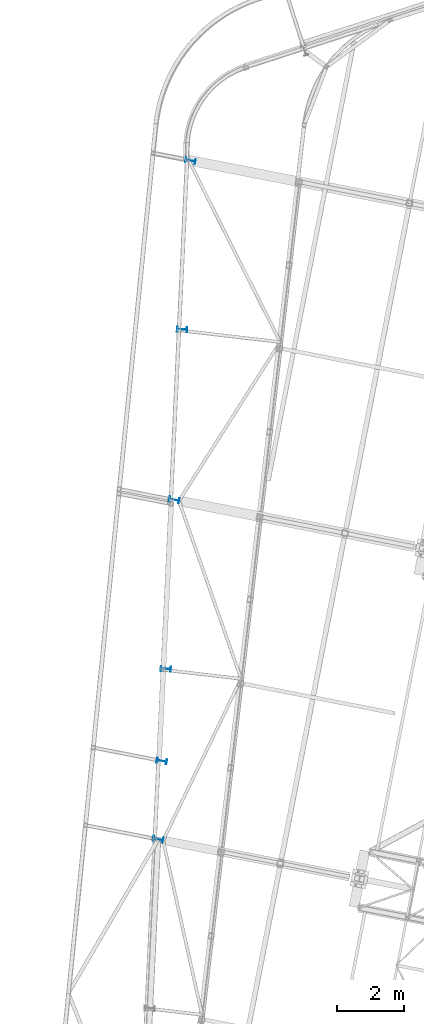
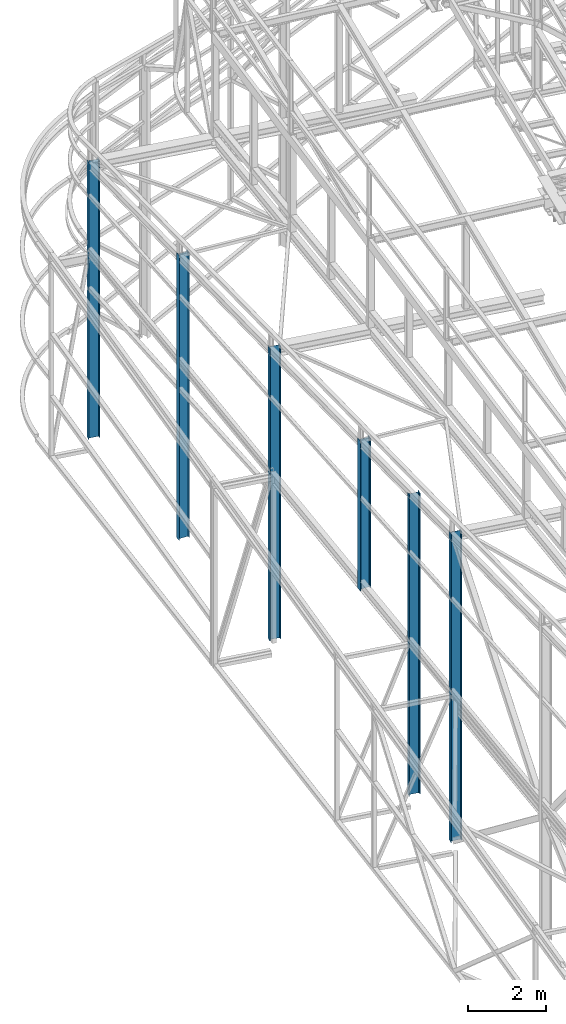
# One storey, part 5 of 215: 6 columns, 6 elements without a shape of their own.
"""IFC2X3 building model written with IfcOpenShell, lengths in millimetres."""

from ifc_helpers import new_model, si_unit, frame, origin_with_axes, origin_2d_with_axis, place, context, subcontext, project, spatial, i_section, extrude, material, type_object, element, aggregate, save


model = new_model("IFC2X3")

# Units and contexts
model_context = context("Model", 3, precision=1e-05, world=origin_with_axes())
body_context = subcontext(model_context, "Body", "Model", "MODEL_VIEW")
ifc_project = project(units=[si_unit("LENGTHUNIT", "METRE", prefix="MILLI"), si_unit("AREAUNIT", "SQUARE_METRE"), si_unit("VOLUMEUNIT", "CUBIC_METRE"), si_unit("MASSUNIT", "GRAM", prefix="KILO"), si_unit("TIMEUNIT", "SECOND"), si_unit("PLANEANGLEUNIT", "RADIAN"), si_unit("SOLIDANGLEUNIT", "STERADIAN"), si_unit("THERMODYNAMICTEMPERATUREUNIT", "DEGREE_CELSIUS"), si_unit("LUMINOUSINTENSITYUNIT", "LUMEN")], contexts=[model_context])

# Site, building, storey
site_placement = place(None, origin_with_axes())
site = spatial("IfcSite", under=ifc_project, at=site_placement, CompositionType="ELEMENT")
building_placement = place(site_placement, origin_with_axes())
building = spatial("IfcBuilding", under=site, at=building_placement, Name="Undefined", CompositionType="ELEMENT")
storey_placement = place(building_placement, origin_with_axes())
storey = spatial("IfcBuildingStorey", under=building, at=storey_placement, Name="Undefined", CompositionType="ELEMENT", Elevation=0.0)

# Assembly, column
assembly_1_placement = place(storey_placement, origin_with_axes())
assembly_1 = element("IfcElementAssembly", 1, at=assembly_1_placement, inside=storey, Name="Steel Assembly", AssemblyPlace="NOTDEFINED", PredefinedType="RIGID_FRAME")
ifc_material = material(Name="STEEL/S275JR")
column_type = type_object("IfcColumnType", Name="IPE300", PredefinedType="NOTDEFINED")
column_1_placement = place(assembly_1_placement, frame((38415.167229992, 39235.4405524724, 4711.42611583732), z_axis=(0.0, 0.0, 1.0), x_axis=(-0.998865584637834, 0.0476187339827342, 0.0)))
column_1 = element("IfcColumn", 2, at=column_1_placement, type_object=column_type, material=ifc_material, Name="MONTANT", ObjectType="IPE300", context=body_context, shape_type="SweptSolid", body=[
    extrude(i_section(OverallWidth=150.0, OverallDepth=300.0, WebThickness=7.099999905, FlangeThickness=10.69999981, FilletRadius=15.0, at=origin_2d_with_axis()), frame((0.0, 0.0, 4682.42655784065), z_axis=(0.0, 0.0, -1.0), x_axis=(0.0, 1.0, 0.0)), (0.0, 0.0, 1.0), 4682.4),
])
aggregate(assembly_1, [column_1])

assembly_2_placement = place(storey_placement, origin_with_axes())
assembly_2 = element("IfcElementAssembly", 3, at=assembly_2_placement, inside=storey, Name="Steel Assembly", AssemblyPlace="NOTDEFINED", PredefinedType="RIGID_FRAME")
column_2_placement = place(assembly_2_placement, frame((38896.164283478, 49328.6883093146, 0.00149246255637933), z_axis=(0.0, 0.0, 1.0), x_axis=(-0.998865584637834, 0.0476187339827342, 0.0)))
column_2 = element("IfcColumn", 4, at=column_2_placement, type_object=column_type, material=ifc_material, Name="MONTANT", ObjectType="IPE300", context=body_context, shape_type="SweptSolid", body=[
    extrude(i_section(OverallWidth=150.0, OverallDepth=300.0, WebThickness=7.099999905, FlangeThickness=10.69999981, FilletRadius=15.0, at=origin_2d_with_axis()), frame((0.0, 0.0, 8896.05310158073), z_axis=(0.0, 0.0, -1.0), x_axis=(0.0, 1.0, 0.0)), (0.0, 0.0, 1.0), 8896.1),
])
aggregate(assembly_2, [column_2])

assembly_3_placement = place(storey_placement, origin_with_axes())
assembly_3 = element("IfcElementAssembly", 5, at=assembly_3_placement, inside=storey, Name="Steel Assembly", AssemblyPlace="NOTDEFINED", PredefinedType="RIGID_FRAME")
column_3_placement = place(assembly_3_placement, frame((38293.8876902089, 36495.289165562, 0.00149200970825802), z_axis=(0.0, 0.0, 1.0), x_axis=(-0.981422412140383, 0.191859451027444, 0.0)))
column_3 = element("IfcColumn", 6, at=column_3_placement, type_object=column_type, material=ifc_material, Name="MONTANT", ObjectType="IPE300", context=body_context, shape_type="SweptSolid", body=[
    extrude(i_section(OverallWidth=150.0, OverallDepth=300.0, WebThickness=7.099999905, FlangeThickness=10.69999981, FilletRadius=15.0, at=origin_2d_with_axis()), frame((0.0, 0.0, 9389.93449272094), z_axis=(0.0, 0.0, -1.0), x_axis=(0.0, 1.0, 0.0)), (0.0, 0.0, 1.0), 9389.9),
])
aggregate(assembly_3, [column_3])

assembly_4_placement = place(storey_placement, origin_with_axes())
assembly_4 = element("IfcElementAssembly", 7, at=assembly_4_placement, inside=storey, Name="Steel Assembly", AssemblyPlace="NOTDEFINED", PredefinedType="RIGID_FRAME")
column_4_placement = place(assembly_4_placement, frame((38663.8672944717, 44259.39881284, 0.00149246245018797), z_axis=(0.0, 0.0, 1.0), x_axis=(-0.981475092367809, 0.1915897780718, 0.0)))
column_4 = element("IfcColumn", 8, at=column_4_placement, type_object=column_type, material=ifc_material, Name="MONTANT", ObjectType="IPE300", context=body_context, shape_type="SweptSolid", body=[
    extrude(i_section(OverallWidth=150.0, OverallDepth=300.0, WebThickness=7.099999905, FlangeThickness=10.69999981, FilletRadius=15.0, at=origin_2d_with_axis()), frame((0.0, -7.27595761418343e-12, 9144.6443180888), z_axis=(0.0, 0.0, -1.0), x_axis=(0.0, 1.0, 0.0)), (0.0, 0.0, 1.0), 9144.6),
])
aggregate(assembly_4, [column_4])

assembly_5_placement = place(storey_placement, origin_with_axes())
assembly_5 = element("IfcElementAssembly", 9, at=assembly_5_placement, inside=storey, Name="Steel Assembly", AssemblyPlace="NOTDEFINED", PredefinedType="RIGID_FRAME")
column_5_placement = place(assembly_5_placement, frame((38182.8697809645, 34164.0437884615, 0.00149201896214947), z_axis=(0.0, 0.0, 1.0), x_axis=(-0.981422412140383, 0.191859451027444, 0.0)))
column_5 = element("IfcColumn", 10, at=column_5_placement, type_object=column_type, material=ifc_material, Name="MONTANT", ObjectType="IPE300", context=body_context, shape_type="SweptSolid", body=[
    extrude(i_section(OverallWidth=150.0, OverallDepth=300.0, WebThickness=7.099999905, FlangeThickness=10.69999981, FilletRadius=15.0, at=origin_2d_with_axis()), frame((0.0, 0.0, 9644.8028428356), z_axis=(0.0, 0.0, -1.0), x_axis=(0.0, 1.0, 0.0)), (0.0, 0.0, 1.0), 9644.8),
])
aggregate(assembly_5, [column_5])

assembly_6_placement = place(storey_placement, origin_with_axes())
assembly_6 = element("IfcElementAssembly", 11, at=assembly_6_placement, inside=storey, Name="Steel Assembly", AssemblyPlace="NOTDEFINED", PredefinedType="RIGID_FRAME")
column_6_placement = place(assembly_6_placement, frame((39144.8069404373, 54350.1887481964, 0.00149231641541128), z_axis=(0.0, 0.0, 1.0), x_axis=(-0.981257700360074, 0.19270009207071, 0.0)))
column_6 = element("IfcColumn", 12, at=column_6_placement, type_object=column_type, material=ifc_material, Name="MONTANT", ObjectType="IPE300", context=body_context, shape_type="SweptSolid", body=[
    extrude(i_section(OverallWidth=150.0, OverallDepth=300.0, WebThickness=7.099999905, FlangeThickness=10.69999981, FilletRadius=15.0, at=origin_2d_with_axis()), frame((0.0, 0.0, 8654.92358603991), z_axis=(0.0, 0.0, -1.0), x_axis=(0.0, 1.0, 0.0)), (0.0, 0.0, 1.0), 8654.9),
])
aggregate(assembly_6, [column_6])

save(model, "model.ifc")
